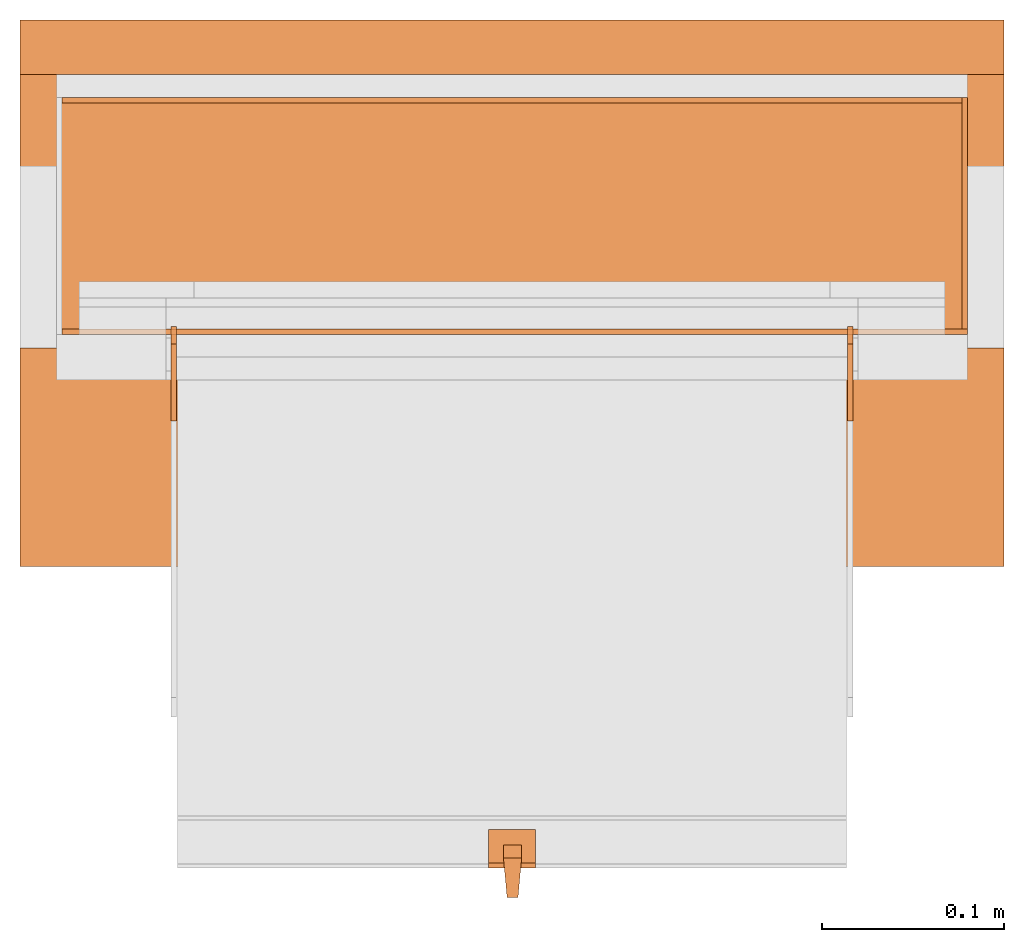
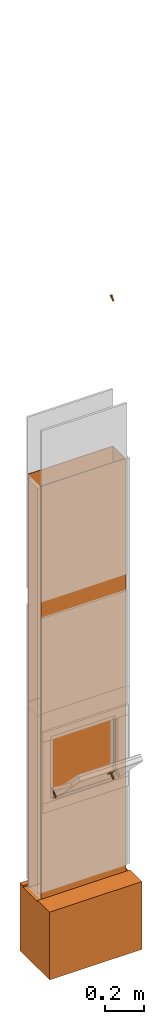
# One storey, part 4 of 4: 12 proxies, 1 opening.
"""IFC2X3 building model written with IfcOpenShell, lengths in metres."""

from ifc_helpers import new_model, entity, si_unit, converted_unit, derived_unit, money_unit, direction, frame, origin_with_axes, origin_2d_with_axis, place, context, subcontext, project, spatial, polyline, rectangle, outline, extrude, boolean, faceted_brep, source, transform, mapped, material, type_object, element, save


model = new_model("IFC2X3")

# Units and contexts
model_context = context("Model", 3, precision=1e-05, world=origin_with_axes(), true_north=direction((0.0, 1.0)))
plan_context = context("Plan", 3, precision=1e-05, world=origin_with_axes(), true_north=direction((0.0, 1.0)))
body_context = subcontext(model_context, "Body", "Model", "MODEL_VIEW")
ifc_project = project(units=[si_unit("LENGTHUNIT", "METRE"), si_unit("AREAUNIT", "SQUARE_METRE"), si_unit("VOLUMEUNIT", "CUBIC_METRE"), converted_unit("PLANEANGLEUNIT", "DEGREE", entity("IfcPlaneAngleMeasure", 0.0174532925199), si_unit("PLANEANGLEUNIT", "RADIAN"), dimensions=[0, 0, 0, 0, 0, 0, 0]), si_unit("SOLIDANGLEUNIT", "STERADIAN"), money_unit("CHF"), converted_unit("TIMEUNIT", "Year", entity("IfcTimeMeasure", 31556926.0), si_unit("TIMEUNIT", "SECOND"), dimensions=[0, 0, 1, 0, 0, 0, 0]), si_unit("MASSUNIT", "GRAM", prefix="KILO"), si_unit("THERMODYNAMICTEMPERATUREUNIT", "DEGREE_CELSIUS"), si_unit("LUMINOUSINTENSITYUNIT", "LUMEN"), si_unit("ENERGYUNIT", "JOULE", prefix="MEGA"), derived_unit("THERMALCONDUCTANCEUNIT", [(si_unit("POWERUNIT", "WATT"), 1), (si_unit("LENGTHUNIT", "METRE"), -1), (si_unit("THERMODYNAMICTEMPERATUREUNIT", "KELVIN"), -1)]), derived_unit("SPECIFICHEATCAPACITYUNIT", [(si_unit("ENERGYUNIT", "JOULE"), 1), (si_unit("MASSUNIT", "GRAM", prefix="KILO"), -1), (si_unit("THERMODYNAMICTEMPERATUREUNIT", "KELVIN"), -1)]), derived_unit("MASSDENSITYUNIT", [(si_unit("MASSUNIT", "GRAM", prefix="KILO"), 1), (si_unit("VOLUMEUNIT", "CUBIC_METRE"), -1)])], contexts=[model_context, plan_context])

# Site, building, storey
site_placement = place(None, origin_with_axes())
site = spatial("IfcSite", under=ifc_project, at=site_placement, CompositionType="ELEMENT")
building_placement = place(site_placement, origin_with_axes())
building = spatial("IfcBuilding", under=site, at=building_placement, CompositionType="ELEMENT")
storey_placement = place(building_placement, origin_with_axes())
storey = spatial("IfcBuildingStorey", under=building, at=storey_placement, Name="EG00", CompositionType="ELEMENT", Elevation=0.0)

# Proxies
ifc_material_1 = material(Name="Metall, Stahl")
building_element_proxy_type_1 = type_object("IfcBuildingElementProxyType", Name="Metall, Stahl 3", PredefinedType="NOTDEFINED")
proxy_1_placement = place(storey_placement, frame((2.05655524907, -8.09743070606, 0.0), z_axis=(0.0, 0.0, 1.0), x_axis=(-1.0, 0.0, 0.0)))
element("IfcBuildingElementProxy", 1, at=proxy_1_placement, inside=storey, type_object=building_element_proxy_type_1, material=ifc_material_1, Name="Wand-008", context=body_context, shape_type="CSG", body=[
    boolean("DIFFERENCE", boolean("DIFFERENCE", extrude(outline(polyline([(0.0, 0.0), (0.5, 0.0), (0.5, 0.003), (0.0, 0.003), (0.0, 0.0)])), origin_with_axes(), (0.0, 0.0, 1.0), 1.15), faceted_brep([(0.497, 0.003, 1.15), (0.497, 0.0, 1.15), (0.5, 0.0, 1.15), (0.5, 0.003, 1.15), (0.497, 0.0, 0.0), (0.497, 0.003, 0.0), (0.5, 0.0, 0.0), (0.5, 0.003, 0.0)], [[[0, 1, 2, 3]], [[4, 1, 0, 5]], [[1, 4, 6, 2]], [[2, 6, 7, 3]], [[5, 0, 3, 7]], [[4, 5, 7, 6]]])), faceted_brep([(0.003, 0.0, 0.0), (0.003, 0.0, 1.15), (0.0, 0.0, 1.15), (0.0, 0.0, 0.0), (0.003, 0.003, 1.15), (0.003, 0.003, 0.0), (0.0, 0.003, 1.15), (0.0, 0.003, 0.0)], [[[0, 1, 2, 3]], [[4, 1, 0, 5]], [[1, 4, 6, 2]], [[6, 7, 3, 2]], [[5, 0, 3, 7]], [[4, 5, 7, 6]]])),
])
proxy_2_placement = place(storey_placement, frame((2.05655524907, -8.22743070606, 0.0), z_axis=(0.0, 0.0, 1.0), x_axis=(0.0, 1.0, 0.0)))
element("IfcBuildingElementProxy", 2, at=proxy_2_placement, inside=storey, type_object=building_element_proxy_type_1, material=ifc_material_1, Name="Wand-007", context=body_context, shape_type="CSG", body=[
    boolean("DIFFERENCE", extrude(outline(polyline([(0.0, 0.0), (0.13, 0.0), (0.13, 0.003), (0.0, 0.003), (0.0, 0.0)])), origin_with_axes(), (0.0, 0.0, 1.0), 1.15), faceted_brep([(0.003, 0.0, 0.0), (0.003, 0.0, 1.15), (0.0, 0.0, 1.15), (0.0, 0.0, 0.0), (0.003, 0.003, 1.15), (0.003, 0.003, 0.0), (0.0, 0.003, 1.15), (0.0, 0.003, 0.0)], [[[0, 1, 2, 3]], [[4, 1, 0, 5]], [[1, 4, 6, 2]], [[6, 7, 3, 2]], [[5, 0, 3, 7]], [[4, 5, 7, 6]]])),
])

# Proxy, opening
proxy_3_placement = place(storey_placement, frame((1.55655524907, -8.22743070606, 0.0), z_axis=(0.0, 0.0, 1.0), x_axis=(1.0, 0.0, 0.0)))
proxy_3 = element("IfcBuildingElementProxy", 3, at=proxy_3_placement, inside=storey, type_object=building_element_proxy_type_1, material=ifc_material_1, Name="Wand-006", context=body_context, shape_type="CSG", body=[
    boolean("DIFFERENCE", extrude(outline(polyline([(0.0, 0.0), (0.5, 0.0), (0.5, 0.003), (0.0, 0.003), (0.0, 0.0)])), origin_with_axes(), (0.0, 0.0, 1.0), 1.15), faceted_brep([(0.003, 0.0, 1.15), (0.003, 0.003, 1.15), (0.0, 0.003, 1.15), (0.0, 0.0, 1.15), (0.003, 0.003, 0.0), (0.003, 0.0, 0.0), (0.0, 0.003, 0.0), (0.0, 0.0, 0.0)], [[[0, 1, 2, 3]], [[4, 1, 0, 5]], [[1, 4, 6, 2]], [[2, 6, 7, 3]], [[5, 0, 3, 7]], [[4, 5, 7, 6]]])),
])
opening_placement = place(proxy_3_placement, frame((-1.55655524907, 8.22743070606, 0.0), z_axis=(0.0, 0.0, 1.0), x_axis=(1.0, 0.0, 0.0)))
element("IfcOpeningElement", 4, at=opening_placement, cuts=proxy_3, Name="016", context=body_context, shape_type="SweptSolid", body=[
    extrude(rectangle(XDim=0.38, YDim=0.38, at=origin_2d_with_axis()), frame((1.80655524907, -8.25243070606, 0.8), z_axis=(0.0, -1.0, 0.0), x_axis=(1.0, 0.0, 0.0)), (0.0, 0.0, -1.0), 0.031),
])

# Proxies
proxy_4_placement = place(storey_placement, frame((2.05655524907, -8.09743070606, 1.15), z_axis=(0.0, 0.0, 1.0), x_axis=(-1.0, 0.0, 0.0)))
element("IfcBuildingElementProxy", 5, at=proxy_4_placement, inside=storey, type_object=building_element_proxy_type_1, material=ifc_material_1, Name="Wand-008", context=body_context, shape_type="CSG", body=[
    boolean("DIFFERENCE", boolean("DIFFERENCE", extrude(outline(polyline([(0.0, 0.0), (0.5, 0.0), (0.5, 0.003), (0.0, 0.003), (0.0, 0.0)])), origin_with_axes(), (0.0, 0.0, 1.0), 1.41), faceted_brep([(0.497, 0.003, 1.41), (0.497, 0.0, 1.41), (0.5, 0.0, 1.41), (0.5, 0.003, 1.41), (0.497, 0.0, 0.0), (0.497, 0.003, 0.0), (0.5, 0.0, 0.0), (0.5, 0.003, 0.0)], [[[0, 1, 2, 3]], [[4, 1, 0, 5]], [[1, 4, 6, 2]], [[2, 6, 7, 3]], [[5, 0, 3, 7]], [[4, 5, 7, 6]]])), faceted_brep([(0.003, 0.0, 0.0), (0.003, 0.0, 1.41), (0.0, 0.0, 1.41), (0.0, 0.0, 0.0), (0.003, 0.003, 1.41), (0.003, 0.003, 0.0), (0.0, 0.003, 1.41), (0.0, 0.003, 0.0)], [[[0, 1, 2, 3]], [[4, 1, 0, 5]], [[1, 4, 6, 2]], [[6, 7, 3, 2]], [[5, 0, 3, 7]], [[4, 5, 7, 6]]])),
])
proxy_5_placement = place(storey_placement, frame((2.05655524907, -8.22743070606, 1.15), z_axis=(0.0, 0.0, 1.0), x_axis=(0.0, 1.0, 0.0)))
element("IfcBuildingElementProxy", 6, at=proxy_5_placement, inside=storey, type_object=building_element_proxy_type_1, material=ifc_material_1, Name="Wand-007", context=body_context, shape_type="CSG", body=[
    boolean("DIFFERENCE", extrude(outline(polyline([(0.0, 0.0), (0.13, 0.0), (0.13, 0.003), (0.0, 0.003), (0.0, 0.0)])), origin_with_axes(), (0.0, 0.0, 1.0), 1.41), faceted_brep([(0.003, 0.0, 0.0), (0.003, 0.0, 1.41), (0.0, 0.0, 1.41), (0.0, 0.0, 0.0), (0.003, 0.003, 1.41), (0.003, 0.003, 0.0), (0.0, 0.003, 1.41), (0.0, 0.003, 0.0)], [[[0, 1, 2, 3]], [[4, 1, 0, 5]], [[1, 4, 6, 2]], [[6, 7, 3, 2]], [[5, 0, 3, 7]], [[4, 5, 7, 6]]])),
])
proxy_6_placement = place(storey_placement, frame((1.55655524907, -8.22743070606, 1.15), z_axis=(0.0, 0.0, 1.0), x_axis=(1.0, 0.0, 0.0)))
element("IfcBuildingElementProxy", 7, at=proxy_6_placement, inside=storey, type_object=building_element_proxy_type_1, material=ifc_material_1, Name="Wand-006", context=body_context, shape_type="CSG", body=[
    boolean("DIFFERENCE", extrude(outline(polyline([(0.0, 0.0), (0.5, 0.0), (0.5, 0.003), (0.0, 0.003), (0.0, 0.0)])), origin_with_axes(), (0.0, 0.0, 1.0), 1.41), faceted_brep([(0.003, 0.0, 1.41), (0.003, 0.003, 1.41), (0.0, 0.003, 1.41), (0.0, 0.0, 1.41), (0.003, 0.003, 0.0), (0.003, 0.0, 0.0), (0.0, 0.003, 0.0), (0.0, 0.0, 0.0)], [[[0, 1, 2, 3]], [[4, 1, 0, 5]], [[1, 4, 6, 2]], [[2, 6, 7, 3]], [[5, 0, 3, 7]], [[4, 5, 7, 6]]])),
])
ifc_material_2 = material(Name="Luft, horizontal")
building_element_proxy_type_2 = type_object("IfcBuildingElementProxyType", Name="Luft, horizontal 420", PredefinedType="NOTDEFINED")
proxy_7_placement = place(storey_placement, frame((1.53655524907, -8.35493070606, 0.01), z_axis=(0.0, 0.0, 1.0), x_axis=(1.0, 0.0, 0.0)))
element("IfcBuildingElementProxy", 8, at=proxy_7_placement, inside=storey, type_object=building_element_proxy_type_2, material=ifc_material_2, Name="Decke-007", context=body_context, shape_type="CSG", body=[
    boolean("DIFFERENCE", extrude(outline(polyline([(0.0, 0.0), (0.54, 0.0), (0.54, 0.3), (0.0, 0.3), (0.0, 0.0)])), frame((0.0, 0.0, -0.42), z_axis=(0.0, 0.0, 1.0), x_axis=(1.0, 0.0, 0.0)), (0.0, 0.0, 1.0), 0.42), faceted_brep([(0.54, 0.12, -0.01), (0.54, 0.27, -0.01), (0.54, 0.27, 0.0), (0.54, 0.12, 0.0), (0.0, 0.12, -0.01), (0.0, 0.27, -0.01), (0.0, 0.27, 0.0), (0.0, 0.12, 0.0)], [[[0, 1, 2, 3]], [[1, 0, 4, 5]], [[6, 2, 1, 5]], [[7, 3, 2, 6]], [[0, 3, 7, 4]], [[4, 7, 6, 5]]])),
])
ifc_material_3 = material(Name="Metall, Aluminium")
building_element_proxy_type_3 = type_object("IfcBuildingElementProxyType", Name="Metall, Aluminium", PredefinedType="NOTDEFINED")
shared_shape_1 = source(origin_with_axes(), body_context, "Body", "Brep", [
    faceted_brep([(16.3891379247, -3.43334637562, 1.097), (16.3891379247, -3.44334637562, 1.097), (16.3921379247, -3.43534637562, 1.13058255688), (16.3991379247, -3.43334637562, 1.097), (16.3991379247, -3.44334637562, 1.097), (16.3921379247, -3.44134637562, 1.13058255688), (16.3961379247, -3.43523159518, 1.13058255688), (16.3961379247, -3.4414517679, 1.13058255688)], [[[0, 1, 2]], [[1, 0, 3, 4]], [[1, 5, 2]], [[0, 2, 3]], [[4, 3, 6]], [[5, 1, 4]], [[2, 5, 7]], [[3, 2, 6]], [[6, 7, 4]], [[7, 5, 4]], [[2, 7, 6]]]),
])
for number, where, z_axis, x_axis, name in (
    (9, (5.24519933596, -19.2080620883, 13.3444423362), (0.0, -0.713898265506, -0.700249431636), (0.0, 0.700249431636, -0.713898265506), "Wand-008"),
    (10, (5.24519933596, -19.2080620883, 16.3044423362), (0.0, -0.713898265506, -0.700249431636), (0.0, 0.700249431636, -0.713898265506), "Wand-008"),
):
    element("IfcBuildingElementProxy", number, at=place(storey_placement, frame(where, z_axis=z_axis, x_axis=x_axis)), inside=storey, type_object=building_element_proxy_type_3, material=ifc_material_3, Name=name, context=body_context, shape_type="MappedRepresentation", body=[
        mapped(shared_shape_1, transform((0.0, 0.0, 0.0))),
    ])
shared_shape_2 = source(origin_with_axes(), body_context, "Body", "Brep", [
    faceted_brep([(16.1345115895, -3.59726483298, 0.726478855326), (16.1345115895, -3.60026483298, 0.726478855326), (16.1345115895, -3.60026483298, 0.776478855326), (16.1345115895, -3.59726483298, 0.776478855326), (16.1525115895, -3.60026483298, 0.726478855326), (16.1525115895, -3.59726483298, 0.726478855326), (16.1525115895, -3.60026483298, 0.776478855326), (16.1525115895, -3.59726483298, 0.776478855326)], [[[0, 1, 2, 3]], [[4, 1, 0, 5]], [[1, 4, 6, 2]], [[2, 6, 7, 3]], [[0, 3, 7, 5]], [[4, 5, 7, 6]]]),
])
for number, where, z_axis, x_axis, name in (
    (11, (5.21982008204, -16.2173099117, 14.7145311427), (0.0, -0.846133712697, -0.532970674838), (0.0, 0.532970674838, -0.846133712697), "Wand-005"),
    (12, (5.59082008204, -16.2173099117, 14.7145311427), (0.0, -0.846133712697, -0.532970674838), (0.0, 0.532970674838, -0.846133712697), "Wand-005"),
):
    element("IfcBuildingElementProxy", number, at=place(storey_placement, frame(where, z_axis=z_axis, x_axis=x_axis)), inside=storey, type_object=building_element_proxy_type_3, material=ifc_material_3, Name=name, context=body_context, shape_type="MappedRepresentation", body=[
        mapped(shared_shape_2, transform((0.0, 0.0, 0.0))),
    ])
shared_shape_3 = source(origin_with_axes(), body_context, "Body", "Brep", [
    faceted_brep([(16.3888858635, -3.43025891523, 1.114), (16.3888858635, -3.43025891523, 1.14), (16.3888858635, -3.40425891523, 1.14), (16.3888858635, -3.40425891523, 1.114), (16.3928858635, -3.43025891523, 1.114), (16.3928858635, -3.43025891523, 1.14), (16.3928858635, -3.40825891523, 1.14), (16.3928858635, -3.40425891523, 1.14), (16.3928858635, -3.40425891523, 1.114), (16.3928858635, -3.40825891523, 1.114)], [[[0, 1, 2, 3]], [[1, 0, 4]], [[2, 1, 5, 6, 7]], [[3, 2, 7, 8]], [[0, 3, 8, 9, 4]], [[1, 4, 5]], [[6, 5, 4]], [[6, 9, 8, 7]], [[9, 6, 4]]]),
])
proxy_8_placement = place(storey_placement, frame((5.2238141643, 3.98081117247, 11.5470677443), z_axis=(0.0, -0.700249431637, 0.713898265506), x_axis=(0.0, -0.713898265506, -0.700249431637)))
element("IfcBuildingElementProxy", 13, at=proxy_8_placement, inside=storey, type_object=building_element_proxy_type_3, material=ifc_material_3, Name="Wand-007", context=body_context, shape_type="MappedRepresentation", body=[
    mapped(shared_shape_3, transform((0.0, 0.0, 0.0))),
])

save(model, "model.ifc")
